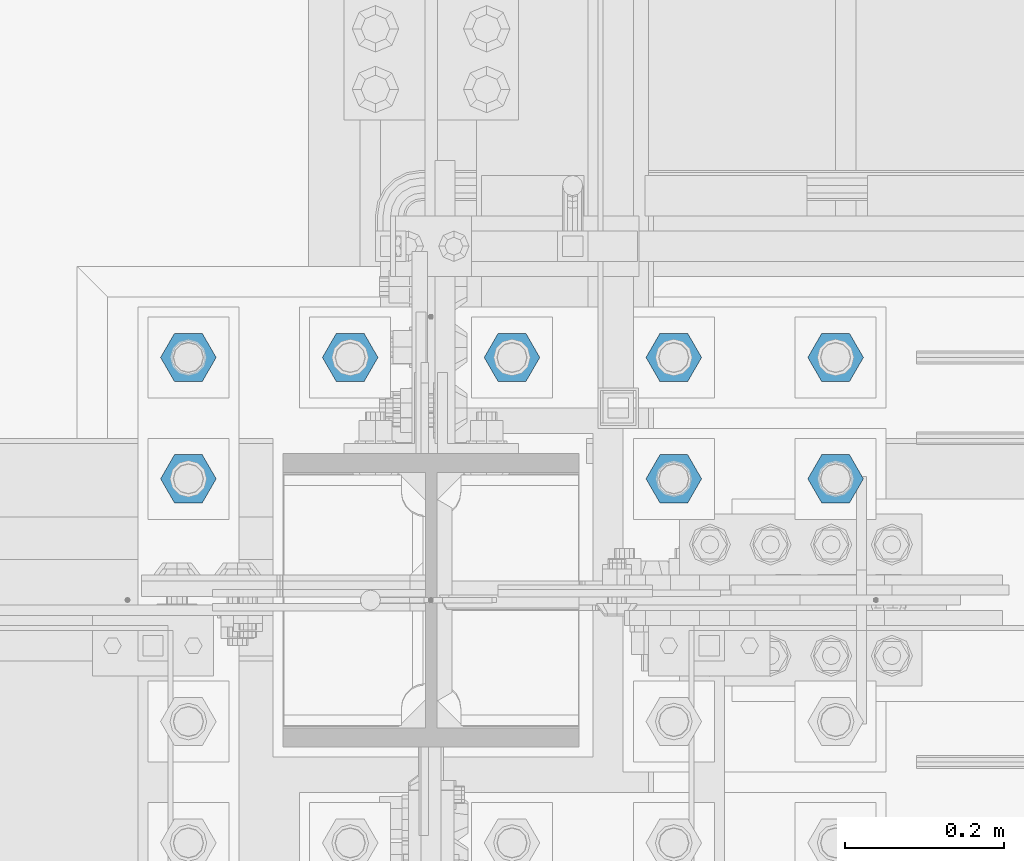
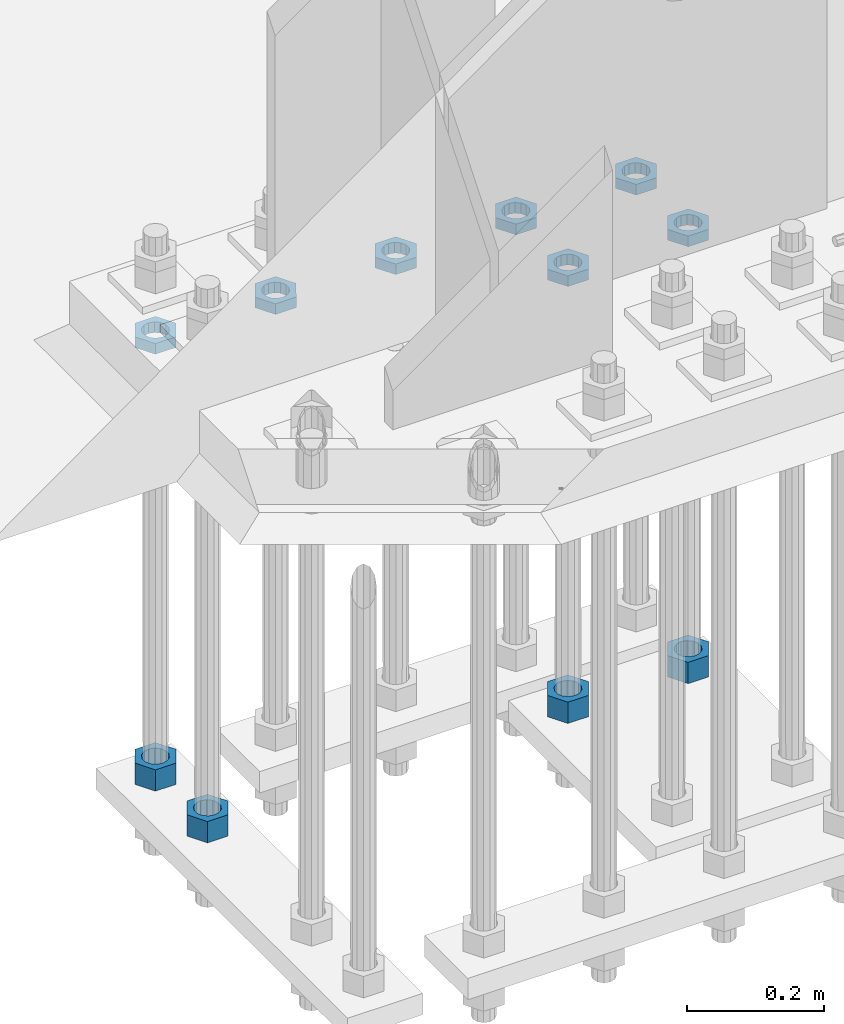
# One storey, part 2826 of 3843: 11 beams, 1 element without a shape of its own.
"""IFC2X3 building model written with IfcOpenShell, lengths in millimetres."""

from ifc_helpers import new_model, si_unit, frame, origin_with_axes, place, context, subcontext, project, spatial, faceted_brep, material, type_object, element, aggregate, save


model = new_model("IFC2X3")

# Units and contexts
model_context = context("Model", 3, precision=1e-05, world=origin_with_axes())
body_context = subcontext(model_context, "Body", "Model", "MODEL_VIEW")
ifc_project = project(units=[si_unit("LENGTHUNIT", "METRE", prefix="MILLI"), si_unit("AREAUNIT", "SQUARE_METRE"), si_unit("VOLUMEUNIT", "CUBIC_METRE"), si_unit("MASSUNIT", "GRAM", prefix="KILO"), si_unit("TIMEUNIT", "SECOND"), si_unit("PLANEANGLEUNIT", "RADIAN"), si_unit("SOLIDANGLEUNIT", "STERADIAN"), si_unit("THERMODYNAMICTEMPERATUREUNIT", "DEGREE_CELSIUS"), si_unit("LUMINOUSINTENSITYUNIT", "LUMEN")], contexts=[model_context])

# Site, building, storey
site_placement = place(None, origin_with_axes())
site = spatial("IfcSite", under=ifc_project, at=site_placement, CompositionType="ELEMENT")
building_placement = place(site_placement, origin_with_axes())
building = spatial("IfcBuilding", under=site, at=building_placement, Name="Undefined", CompositionType="ELEMENT")
storey_placement = place(building_placement, origin_with_axes())
storey = spatial("IfcBuildingStorey", under=building, at=storey_placement, Name="Undefined", CompositionType="ELEMENT", Elevation=0.0)

# Assembly, beams
assembly_placement = place(storey_placement, origin_with_axes())
assembly = element("IfcElementAssembly", 1, at=assembly_placement, inside=storey, Name="TEMPLATE", AssemblyPlace="NOTDEFINED", PredefinedType="RIGID_FRAME")
ifc_material = material(Name="STEEL/A572-50")
beam_type_1 = type_object("IfcBeamType", Name="1-1/2_HEAVY_HEX_NUT", PredefinedType="NOTDEFINED")
beam_1_placement = place(assembly_placement, frame((56438.8, 25768.3, 28841.7000015259), z_axis=(0.0, 1.0, 0.0), x_axis=(0.0, 0.0, -1.0)))
beam_1 = element("IfcBeam", 2, at=beam_1_placement, type_object=beam_type_1, material=ifc_material, Name="NUT", ObjectType="1-1/2_HEAVY_HEX_NUT", context=body_context, shape_type="Brep", body=[
    faceted_brep([(0.0, -34.9199981689453, 0.0), (0.0, -17.4599990844727, -30.25), (38.0999999999985, -17.4599990844727, -30.25), (38.0999999999985, -34.9199981689453, 0.0), (0.0, 17.4599990844727, -30.25), (38.0999999999985, 17.4599990844727, -30.25), (0.0, 34.9199981689453, 0.0), (38.0999999999985, 34.9199981689453, 0.0), (0.0, 17.4599990844727, 30.25), (38.0999999999985, 17.4599990844727, 30.25), (0.0, -17.4599990844727, 30.25), (38.0999999999985, -17.4599990844727, 30.25), (0.0, 0.0, 20.6399993896484), (0.0, 8.9553601105581, 18.5959968835959), (38.0999999999985, 8.9553601105581, 18.5959968835959), (38.0999999999985, 0.0, 20.6399993896484), (0.0, 16.1370013209525, 12.8688291298167), (38.0999999999985, 16.1370013209525, 12.8688291298167), (0.0, 20.1225115123816, 4.59283194104501), (38.0999999999985, 20.1225115123816, 4.59283194104501), (0.0, 20.1225115123816, -4.59283194104501), (38.0999999999985, 20.1225115123816, -4.59283194104501), (0.0, 16.1370013209525, -12.8688291298167), (38.0999999999985, 16.1370013209525, -12.8688291298167), (0.0, 8.9553601105581, -18.5959968835959), (38.0999999999985, 8.9553601105581, -18.5959968835959), (0.0, 0.0, -20.6399993896484), (38.0999999999985, 0.0, -20.6399993896484), (0.0, -8.9553601105581, -18.5959968835959), (38.0999999999985, -8.9553601105581, -18.5959968835959), (0.0, -16.1370013209525, -12.8688291298167), (38.0999999999985, -16.1370013209525, -12.8688291298167), (0.0, -20.1225115123816, -4.59283194104501), (38.0999999999985, -20.1225115123816, -4.59283194104501), (0.0, -20.1225115123816, 4.59283194104501), (38.0999999999985, -20.1225115123816, 4.59283194104501), (0.0, -16.1370013209525, 12.8688291298167), (38.0999999999985, -16.1370013209525, 12.8688291298167), (0.0, -8.9553601105581, 18.5959968835959), (38.0999999999985, -8.9553601105581, 18.5959968835959)], [[[0, 1, 2, 3]], [[1, 4, 5, 2]], [[4, 6, 7, 5]], [[6, 8, 9, 7]], [[8, 10, 11, 9]], [[10, 0, 3, 11]], [[12, 13, 14, 15]], [[13, 16, 17, 14]], [[16, 18, 19, 17]], [[18, 20, 21, 19]], [[20, 22, 23, 21]], [[22, 24, 25, 23]], [[24, 26, 27, 25]], [[26, 28, 29, 27]], [[28, 30, 31, 29]], [[30, 32, 33, 31]], [[32, 34, 35, 33]], [[34, 36, 37, 35]], [[36, 38, 39, 37]], [[38, 12, 15, 39]], [[5, 7, 9, 11, 3, 2], [17, 19, 21, 23, 25, 27, 29, 31, 33, 35, 37, 39, 15, 14]], [[10, 8, 6, 4, 1, 0], [38, 36, 34, 32, 30, 28, 26, 24, 22, 20, 18, 16, 13, 12]]]),
])
beam_2_placement = place(assembly_placement, frame((56235.6, 25768.3, 28841.7000015259), z_axis=(0.0, 1.0, 0.0), x_axis=(0.0, 0.0, -1.0)))
beam_2 = element("IfcBeam", 3, at=beam_2_placement, type_object=beam_type_1, material=ifc_material, Name="NUT", ObjectType="1-1/2_HEAVY_HEX_NUT", context=body_context, shape_type="Brep", body=[
    faceted_brep([(0.0, -34.9199981689453, 0.0), (0.0, -17.4599990844727, -30.25), (38.0999999999985, -17.4599990844727, -30.25), (38.0999999999985, -34.9199981689453, 0.0), (0.0, 17.4599990844727, -30.25), (38.0999999999985, 17.4599990844727, -30.25), (0.0, 34.9199981689453, 0.0), (38.0999999999985, 34.9199981689453, 0.0), (0.0, 17.4599990844727, 30.25), (38.0999999999985, 17.4599990844727, 30.25), (0.0, -17.4599990844727, 30.25), (38.0999999999985, -17.4599990844727, 30.25), (0.0, 0.0, 20.6399993896484), (0.0, 8.9553601105581, 18.5959968835959), (38.0999999999985, 8.9553601105581, 18.5959968835959), (38.0999999999985, 0.0, 20.6399993896484), (0.0, 16.1370013209525, 12.8688291298167), (38.0999999999985, 16.1370013209525, 12.8688291298167), (0.0, 20.1225115123816, 4.59283194104501), (38.0999999999985, 20.1225115123816, 4.59283194104501), (0.0, 20.1225115123816, -4.59283194104501), (38.0999999999985, 20.1225115123816, -4.59283194104501), (0.0, 16.1370013209525, -12.8688291298167), (38.0999999999985, 16.1370013209525, -12.8688291298167), (0.0, 8.9553601105581, -18.5959968835959), (38.0999999999985, 8.9553601105581, -18.5959968835959), (0.0, 0.0, -20.6399993896484), (38.0999999999985, 0.0, -20.6399993896484), (0.0, -8.9553601105581, -18.5959968835959), (38.0999999999985, -8.9553601105581, -18.5959968835959), (0.0, -16.1370013209525, -12.8688291298167), (38.0999999999985, -16.1370013209525, -12.8688291298167), (0.0, -20.1225115123816, -4.59283194104501), (38.0999999999985, -20.1225115123816, -4.59283194104501), (0.0, -20.1225115123816, 4.59283194104501), (38.0999999999985, -20.1225115123816, 4.59283194104501), (0.0, -16.1370013209525, 12.8688291298167), (38.0999999999985, -16.1370013209525, 12.8688291298167), (0.0, -8.9553601105581, 18.5959968835959), (38.0999999999985, -8.9553601105581, 18.5959968835959)], [[[0, 1, 2, 3]], [[1, 4, 5, 2]], [[4, 6, 7, 5]], [[6, 8, 9, 7]], [[8, 10, 11, 9]], [[10, 0, 3, 11]], [[12, 13, 14, 15]], [[13, 16, 17, 14]], [[16, 18, 19, 17]], [[18, 20, 21, 19]], [[20, 22, 23, 21]], [[22, 24, 25, 23]], [[24, 26, 27, 25]], [[26, 28, 29, 27]], [[28, 30, 31, 29]], [[30, 32, 33, 31]], [[32, 34, 35, 33]], [[34, 36, 37, 35]], [[36, 38, 39, 37]], [[38, 12, 15, 39]], [[5, 7, 9, 11, 3, 2], [17, 19, 21, 23, 25, 27, 29, 31, 33, 35, 37, 39, 15, 14]], [[10, 8, 6, 4, 1, 0], [38, 36, 34, 32, 30, 28, 26, 24, 22, 20, 18, 16, 13, 12]]]),
])
beam_3_placement = place(assembly_placement, frame((55626.0, 25920.7, 28841.7000015259), z_axis=(0.0, -1.0, 0.0), x_axis=(0.0, 0.0, -1.0)))
beam_3 = element("IfcBeam", 4, at=beam_3_placement, type_object=beam_type_1, material=ifc_material, Name="NUT", ObjectType="1-1/2_HEAVY_HEX_NUT", context=body_context, shape_type="Brep", body=[
    faceted_brep([(0.0, -34.9199981689453, 0.0), (0.0, -17.4599990844727, -30.25), (38.0999999999985, -17.4599990844727, -30.25), (38.0999999999985, -34.9199981689453, 0.0), (0.0, 17.4599990844727, -30.25), (38.0999999999985, 17.4599990844727, -30.25), (0.0, 34.9199981689453, 0.0), (38.0999999999985, 34.9199981689453, 0.0), (0.0, 17.4599990844727, 30.25), (38.0999999999985, 17.4599990844727, 30.25), (0.0, -17.4599990844727, 30.25), (38.0999999999985, -17.4599990844727, 30.25), (0.0, 0.0, 20.6399993896484), (0.0, 8.9553601105581, 18.5959968835959), (38.0999999999985, 8.9553601105581, 18.5959968835959), (38.0999999999985, 0.0, 20.6399993896484), (0.0, 16.1370013209525, 12.8688291298167), (38.0999999999985, 16.1370013209525, 12.8688291298167), (0.0, 20.1225115123816, 4.59283194104501), (38.0999999999985, 20.1225115123816, 4.59283194104501), (0.0, 20.1225115123816, -4.59283194104501), (38.0999999999985, 20.1225115123816, -4.59283194104501), (0.0, 16.1370013209525, -12.8688291298167), (38.0999999999985, 16.1370013209525, -12.8688291298167), (0.0, 8.9553601105581, -18.5959968835959), (38.0999999999985, 8.9553601105581, -18.5959968835959), (0.0, 0.0, -20.6399993896484), (38.0999999999985, 0.0, -20.6399993896484), (0.0, -8.9553601105581, -18.5959968835959), (38.0999999999985, -8.9553601105581, -18.5959968835959), (0.0, -16.1370013209525, -12.8688291298167), (38.0999999999985, -16.1370013209525, -12.8688291298167), (0.0, -20.1225115123816, -4.59283194104501), (38.0999999999985, -20.1225115123816, -4.59283194104501), (0.0, -20.1225115123816, 4.59283194104501), (38.0999999999985, -20.1225115123816, 4.59283194104501), (0.0, -16.1370013209525, 12.8688291298167), (38.0999999999985, -16.1370013209525, 12.8688291298167), (0.0, -8.9553601105581, 18.5959968835959), (38.0999999999985, -8.9553601105581, 18.5959968835959)], [[[0, 1, 2, 3]], [[1, 4, 5, 2]], [[4, 6, 7, 5]], [[6, 8, 9, 7]], [[8, 10, 11, 9]], [[10, 0, 3, 11]], [[12, 13, 14, 15]], [[13, 16, 17, 14]], [[16, 18, 19, 17]], [[18, 20, 21, 19]], [[20, 22, 23, 21]], [[22, 24, 25, 23]], [[24, 26, 27, 25]], [[26, 28, 29, 27]], [[28, 30, 31, 29]], [[30, 32, 33, 31]], [[32, 34, 35, 33]], [[34, 36, 37, 35]], [[36, 38, 39, 37]], [[38, 12, 15, 39]], [[5, 7, 9, 11, 3, 2], [17, 19, 21, 23, 25, 27, 29, 31, 33, 35, 37, 39, 15, 14]], [[10, 8, 6, 4, 1, 0], [38, 36, 34, 32, 30, 28, 26, 24, 22, 20, 18, 16, 13, 12]]]),
])
beam_4_placement = place(assembly_placement, frame((55626.0, 25768.3, 28841.7000015259), z_axis=(0.0, -1.0, 0.0), x_axis=(0.0, 0.0, -1.0)))
beam_4 = element("IfcBeam", 5, at=beam_4_placement, type_object=beam_type_1, material=ifc_material, Name="NUT", ObjectType="1-1/2_HEAVY_HEX_NUT", context=body_context, shape_type="Brep", body=[
    faceted_brep([(0.0, -34.9199981689453, 0.0), (0.0, -17.4599990844727, -30.25), (38.0999999999985, -17.4599990844727, -30.25), (38.0999999999985, -34.9199981689453, 0.0), (0.0, 17.4599990844727, -30.25), (38.0999999999985, 17.4599990844727, -30.25), (0.0, 34.9199981689453, 0.0), (38.0999999999985, 34.9199981689453, 0.0), (0.0, 17.4599990844727, 30.25), (38.0999999999985, 17.4599990844727, 30.25), (0.0, -17.4599990844727, 30.25), (38.0999999999985, -17.4599990844727, 30.25), (0.0, 0.0, 20.6399993896484), (0.0, 8.9553601105581, 18.5959968835959), (38.0999999999985, 8.9553601105581, 18.5959968835959), (38.0999999999985, 0.0, 20.6399993896484), (0.0, 16.1370013209525, 12.8688291298167), (38.0999999999985, 16.1370013209525, 12.8688291298167), (0.0, 20.1225115123816, 4.59283194104501), (38.0999999999985, 20.1225115123816, 4.59283194104501), (0.0, 20.1225115123816, -4.59283194104501), (38.0999999999985, 20.1225115123816, -4.59283194104501), (0.0, 16.1370013209525, -12.8688291298167), (38.0999999999985, 16.1370013209525, -12.8688291298167), (0.0, 8.9553601105581, -18.5959968835959), (38.0999999999985, 8.9553601105581, -18.5959968835959), (0.0, 0.0, -20.6399993896484), (38.0999999999985, 0.0, -20.6399993896484), (0.0, -8.9553601105581, -18.5959968835959), (38.0999999999985, -8.9553601105581, -18.5959968835959), (0.0, -16.1370013209525, -12.8688291298167), (38.0999999999985, -16.1370013209525, -12.8688291298167), (0.0, -20.1225115123816, -4.59283194104501), (38.0999999999985, -20.1225115123816, -4.59283194104501), (0.0, -20.1225115123816, 4.59283194104501), (38.0999999999985, -20.1225115123816, 4.59283194104501), (0.0, -16.1370013209525, 12.8688291298167), (38.0999999999985, -16.1370013209525, 12.8688291298167), (0.0, -8.9553601105581, 18.5959968835959), (38.0999999999985, -8.9553601105581, 18.5959968835959)], [[[0, 1, 2, 3]], [[1, 4, 5, 2]], [[4, 6, 7, 5]], [[6, 8, 9, 7]], [[8, 10, 11, 9]], [[10, 0, 3, 11]], [[12, 13, 14, 15]], [[13, 16, 17, 14]], [[16, 18, 19, 17]], [[18, 20, 21, 19]], [[20, 22, 23, 21]], [[22, 24, 25, 23]], [[24, 26, 27, 25]], [[26, 28, 29, 27]], [[28, 30, 31, 29]], [[30, 32, 33, 31]], [[32, 34, 35, 33]], [[34, 36, 37, 35]], [[36, 38, 39, 37]], [[38, 12, 15, 39]], [[5, 7, 9, 11, 3, 2], [17, 19, 21, 23, 25, 27, 29, 31, 33, 35, 37, 39, 15, 14]], [[10, 8, 6, 4, 1, 0], [38, 36, 34, 32, 30, 28, 26, 24, 22, 20, 18, 16, 13, 12]]]),
])
beam_type_2 = type_object("IfcBeamType", Name="1-1/2_HALF_NUT", PredefinedType="NOTDEFINED")
beam_5_placement = place(assembly_placement, frame((56438.8, 25768.3, 29603.7), z_axis=(0.0, 1.0, 0.0), x_axis=(0.0, 0.0, -1.0)))
beam_5 = element("IfcBeam", 6, at=beam_5_placement, type_object=beam_type_2, material=ifc_material, Name="NUT", ObjectType="1-1/2_HALF_NUT", context=body_context, shape_type="Brep", body=[
    faceted_brep([(0.0, -34.9199981689453, 0.0), (0.0, -17.4599990844727, -30.25), (19.0500000000029, -17.4599990844727, -30.25), (19.0500000000029, -34.9199981689453, 0.0), (0.0, 17.4599990844727, -30.25), (19.0500000000029, 17.4599990844727, -30.25), (0.0, 34.9199981689453, 0.0), (19.0500000000029, 34.9199981689453, 0.0), (0.0, 17.4599990844727, 30.25), (19.0500000000029, 17.4599990844727, 30.25), (0.0, -17.4599990844727, 30.25), (19.0500000000029, -17.4599990844727, 30.25), (0.0, 0.0, 20.6399993896484), (0.0, 8.9553601105581, 18.5959968835959), (19.0500000000029, 8.95536011056538, 18.5959968835959), (19.0500000000029, 0.0, 20.6399993896484), (0.0, 16.1370013209525, 12.8688291298167), (19.0500000000029, 16.1370013209489, 12.8688291298167), (0.0, 20.1225115123816, 4.59283194104501), (19.0500000000029, 20.1225115123852, 4.59283194104501), (0.0, 20.1225115123816, -4.59283194104501), (19.0500000000029, 20.1225115123852, -4.59283194104501), (0.0, 16.1370013209525, -12.8688291298167), (19.0500000000029, 16.1370013209489, -12.8688291298167), (0.0, 8.9553601105581, -18.5959968835959), (19.0500000000029, 8.95536011056538, -18.5959968835959), (0.0, 0.0, -20.6399993896484), (19.0500000000029, 0.0, -20.6399993896484), (0.0, -8.9553601105581, -18.5959968835959), (19.0500000000029, -8.95536011056538, -18.5959968835959), (0.0, -16.1370013209525, -12.8688291298167), (19.0500000000029, -16.1370013209489, -12.8688291298167), (0.0, -20.1225115123816, -4.59283194104501), (19.0500000000029, -20.1225115123852, -4.59283194104501), (0.0, -20.1225115123816, 4.59283194104501), (19.0500000000029, -20.1225115123852, 4.59283194104501), (0.0, -16.1370013209525, 12.8688291298167), (19.0500000000029, -16.1370013209489, 12.8688291298167), (0.0, -8.9553601105581, 18.5959968835959), (19.0500000000029, -8.95536011056538, 18.5959968835959)], [[[0, 1, 2, 3]], [[1, 4, 5, 2]], [[4, 6, 7, 5]], [[6, 8, 9, 7]], [[8, 10, 11, 9]], [[10, 0, 3, 11]], [[12, 13, 14, 15]], [[13, 16, 17, 14]], [[16, 18, 19, 17]], [[18, 20, 21, 19]], [[20, 22, 23, 21]], [[22, 24, 25, 23]], [[24, 26, 27, 25]], [[26, 28, 29, 27]], [[28, 30, 31, 29]], [[30, 32, 33, 31]], [[32, 34, 35, 33]], [[34, 36, 37, 35]], [[36, 38, 39, 37]], [[38, 12, 15, 39]], [[5, 7, 9, 11, 3, 2], [17, 19, 21, 23, 25, 27, 29, 31, 33, 35, 37, 39, 15, 14]], [[10, 8, 6, 4, 1, 0], [38, 36, 34, 32, 30, 28, 26, 24, 22, 20, 18, 16, 13, 12]]]),
])
beam_6_placement = place(assembly_placement, frame((56438.8, 25920.7, 29603.7), z_axis=(0.0, 1.0, 0.0), x_axis=(0.0, 0.0, -1.0)))
beam_6 = element("IfcBeam", 7, at=beam_6_placement, type_object=beam_type_2, material=ifc_material, Name="NUT", ObjectType="1-1/2_HALF_NUT", context=body_context, shape_type="Brep", body=[
    faceted_brep([(0.0, -34.9199981689453, 0.0), (0.0, -17.4599990844727, -30.25), (19.0500000000029, -17.4599990844727, -30.25), (19.0500000000029, -34.9199981689453, 0.0), (0.0, 17.4599990844727, -30.25), (19.0500000000029, 17.4599990844727, -30.25), (0.0, 34.9199981689453, 0.0), (19.0500000000029, 34.9199981689453, 0.0), (0.0, 17.4599990844727, 30.25), (19.0500000000029, 17.4599990844727, 30.25), (0.0, -17.4599990844727, 30.25), (19.0500000000029, -17.4599990844727, 30.25), (0.0, 0.0, 20.6399993896484), (0.0, 8.9553601105581, 18.5959968835959), (19.0500000000029, 8.95536011056538, 18.5959968835959), (19.0500000000029, 0.0, 20.6399993896484), (0.0, 16.1370013209525, 12.8688291298167), (19.0500000000029, 16.1370013209489, 12.8688291298167), (0.0, 20.1225115123816, 4.59283194104501), (19.0500000000029, 20.1225115123852, 4.59283194104501), (0.0, 20.1225115123816, -4.59283194104501), (19.0500000000029, 20.1225115123852, -4.59283194104501), (0.0, 16.1370013209525, -12.8688291298167), (19.0500000000029, 16.1370013209489, -12.8688291298167), (0.0, 8.9553601105581, -18.5959968835959), (19.0500000000029, 8.95536011056538, -18.5959968835959), (0.0, 0.0, -20.6399993896484), (19.0500000000029, 0.0, -20.6399993896484), (0.0, -8.9553601105581, -18.5959968835959), (19.0500000000029, -8.95536011056538, -18.5959968835959), (0.0, -16.1370013209525, -12.8688291298167), (19.0500000000029, -16.1370013209489, -12.8688291298167), (0.0, -20.1225115123816, -4.59283194104501), (19.0500000000029, -20.1225115123852, -4.59283194104501), (0.0, -20.1225115123816, 4.59283194104501), (19.0500000000029, -20.1225115123852, 4.59283194104501), (0.0, -16.1370013209525, 12.8688291298167), (19.0500000000029, -16.1370013209489, 12.8688291298167), (0.0, -8.9553601105581, 18.5959968835959), (19.0500000000029, -8.95536011056538, 18.5959968835959)], [[[0, 1, 2, 3]], [[1, 4, 5, 2]], [[4, 6, 7, 5]], [[6, 8, 9, 7]], [[8, 10, 11, 9]], [[10, 0, 3, 11]], [[12, 13, 14, 15]], [[13, 16, 17, 14]], [[16, 18, 19, 17]], [[18, 20, 21, 19]], [[20, 22, 23, 21]], [[22, 24, 25, 23]], [[24, 26, 27, 25]], [[26, 28, 29, 27]], [[28, 30, 31, 29]], [[30, 32, 33, 31]], [[32, 34, 35, 33]], [[34, 36, 37, 35]], [[36, 38, 39, 37]], [[38, 12, 15, 39]], [[5, 7, 9, 11, 3, 2], [17, 19, 21, 23, 25, 27, 29, 31, 33, 35, 37, 39, 15, 14]], [[10, 8, 6, 4, 1, 0], [38, 36, 34, 32, 30, 28, 26, 24, 22, 20, 18, 16, 13, 12]]]),
])
beam_7_placement = place(assembly_placement, frame((56235.6, 25920.7, 29603.7), z_axis=(0.0, 1.0, 0.0), x_axis=(0.0, 0.0, -1.0)))
beam_7 = element("IfcBeam", 8, at=beam_7_placement, type_object=beam_type_2, material=ifc_material, Name="NUT", ObjectType="1-1/2_HALF_NUT", context=body_context, shape_type="Brep", body=[
    faceted_brep([(0.0, -34.9199981689453, 0.0), (0.0, -17.4599990844727, -30.25), (19.0500000000029, -17.4599990844727, -30.25), (19.0500000000029, -34.9199981689453, 0.0), (0.0, 17.4599990844727, -30.25), (19.0500000000029, 17.4599990844727, -30.25), (0.0, 34.9199981689453, 0.0), (19.0500000000029, 34.9199981689453, 0.0), (0.0, 17.4599990844727, 30.25), (19.0500000000029, 17.4599990844727, 30.25), (0.0, -17.4599990844727, 30.25), (19.0500000000029, -17.4599990844727, 30.25), (0.0, 0.0, 20.6399993896484), (0.0, 8.9553601105581, 18.5959968835959), (19.0500000000029, 8.95536011056538, 18.5959968835959), (19.0500000000029, 0.0, 20.6399993896484), (0.0, 16.1370013209525, 12.8688291298167), (19.0500000000029, 16.1370013209489, 12.8688291298167), (0.0, 20.1225115123816, 4.59283194104501), (19.0500000000029, 20.1225115123852, 4.59283194104501), (0.0, 20.1225115123816, -4.59283194104501), (19.0500000000029, 20.1225115123852, -4.59283194104501), (0.0, 16.1370013209525, -12.8688291298167), (19.0500000000029, 16.1370013209489, -12.8688291298167), (0.0, 8.9553601105581, -18.5959968835959), (19.0500000000029, 8.95536011056538, -18.5959968835959), (0.0, 0.0, -20.6399993896484), (19.0500000000029, 0.0, -20.6399993896484), (0.0, -8.9553601105581, -18.5959968835959), (19.0500000000029, -8.95536011056538, -18.5959968835959), (0.0, -16.1370013209525, -12.8688291298167), (19.0500000000029, -16.1370013209489, -12.8688291298167), (0.0, -20.1225115123816, -4.59283194104501), (19.0500000000029, -20.1225115123852, -4.59283194104501), (0.0, -20.1225115123816, 4.59283194104501), (19.0500000000029, -20.1225115123852, 4.59283194104501), (0.0, -16.1370013209525, 12.8688291298167), (19.0500000000029, -16.1370013209489, 12.8688291298167), (0.0, -8.9553601105581, 18.5959968835959), (19.0500000000029, -8.95536011056538, 18.5959968835959)], [[[0, 1, 2, 3]], [[1, 4, 5, 2]], [[4, 6, 7, 5]], [[6, 8, 9, 7]], [[8, 10, 11, 9]], [[10, 0, 3, 11]], [[12, 13, 14, 15]], [[13, 16, 17, 14]], [[16, 18, 19, 17]], [[18, 20, 21, 19]], [[20, 22, 23, 21]], [[22, 24, 25, 23]], [[24, 26, 27, 25]], [[26, 28, 29, 27]], [[28, 30, 31, 29]], [[30, 32, 33, 31]], [[32, 34, 35, 33]], [[34, 36, 37, 35]], [[36, 38, 39, 37]], [[38, 12, 15, 39]], [[5, 7, 9, 11, 3, 2], [17, 19, 21, 23, 25, 27, 29, 31, 33, 35, 37, 39, 15, 14]], [[10, 8, 6, 4, 1, 0], [38, 36, 34, 32, 30, 28, 26, 24, 22, 20, 18, 16, 13, 12]]]),
])
beam_8_placement = place(assembly_placement, frame((56235.6, 25768.3, 29603.7), z_axis=(0.0, 1.0, 0.0), x_axis=(0.0, 0.0, -1.0)))
beam_8 = element("IfcBeam", 9, at=beam_8_placement, type_object=beam_type_2, material=ifc_material, Name="NUT", ObjectType="1-1/2_HALF_NUT", context=body_context, shape_type="Brep", body=[
    faceted_brep([(0.0, -34.9199981689453, 0.0), (0.0, -17.4599990844727, -30.25), (19.0500000000029, -17.4599990844727, -30.25), (19.0500000000029, -34.9199981689453, 0.0), (0.0, 17.4599990844727, -30.25), (19.0500000000029, 17.4599990844727, -30.25), (0.0, 34.9199981689453, 0.0), (19.0500000000029, 34.9199981689453, 0.0), (0.0, 17.4599990844727, 30.25), (19.0500000000029, 17.4599990844727, 30.25), (0.0, -17.4599990844727, 30.25), (19.0500000000029, -17.4599990844727, 30.25), (0.0, 0.0, 20.6399993896484), (0.0, 8.9553601105581, 18.5959968835959), (19.0500000000029, 8.95536011056538, 18.5959968835959), (19.0500000000029, 0.0, 20.6399993896484), (0.0, 16.1370013209525, 12.8688291298167), (19.0500000000029, 16.1370013209489, 12.8688291298167), (0.0, 20.1225115123816, 4.59283194104501), (19.0500000000029, 20.1225115123852, 4.59283194104501), (0.0, 20.1225115123816, -4.59283194104501), (19.0500000000029, 20.1225115123852, -4.59283194104501), (0.0, 16.1370013209525, -12.8688291298167), (19.0500000000029, 16.1370013209489, -12.8688291298167), (0.0, 8.9553601105581, -18.5959968835959), (19.0500000000029, 8.95536011056538, -18.5959968835959), (0.0, 0.0, -20.6399993896484), (19.0500000000029, 0.0, -20.6399993896484), (0.0, -8.9553601105581, -18.5959968835959), (19.0500000000029, -8.95536011056538, -18.5959968835959), (0.0, -16.1370013209525, -12.8688291298167), (19.0500000000029, -16.1370013209489, -12.8688291298167), (0.0, -20.1225115123816, -4.59283194104501), (19.0500000000029, -20.1225115123852, -4.59283194104501), (0.0, -20.1225115123816, 4.59283194104501), (19.0500000000029, -20.1225115123852, 4.59283194104501), (0.0, -16.1370013209525, 12.8688291298167), (19.0500000000029, -16.1370013209489, 12.8688291298167), (0.0, -8.9553601105581, 18.5959968835959), (19.0500000000029, -8.95536011056538, 18.5959968835959)], [[[0, 1, 2, 3]], [[1, 4, 5, 2]], [[4, 6, 7, 5]], [[6, 8, 9, 7]], [[8, 10, 11, 9]], [[10, 0, 3, 11]], [[12, 13, 14, 15]], [[13, 16, 17, 14]], [[16, 18, 19, 17]], [[18, 20, 21, 19]], [[20, 22, 23, 21]], [[22, 24, 25, 23]], [[24, 26, 27, 25]], [[26, 28, 29, 27]], [[28, 30, 31, 29]], [[30, 32, 33, 31]], [[32, 34, 35, 33]], [[34, 36, 37, 35]], [[36, 38, 39, 37]], [[38, 12, 15, 39]], [[5, 7, 9, 11, 3, 2], [17, 19, 21, 23, 25, 27, 29, 31, 33, 35, 37, 39, 15, 14]], [[10, 8, 6, 4, 1, 0], [38, 36, 34, 32, 30, 28, 26, 24, 22, 20, 18, 16, 13, 12]]]),
])
beam_9_placement = place(assembly_placement, frame((56032.4, 25920.7, 29603.7), z_axis=(0.0, -1.0, 0.0), x_axis=(0.0, 0.0, -1.0)))
beam_9 = element("IfcBeam", 10, at=beam_9_placement, type_object=beam_type_2, material=ifc_material, Name="NUT", ObjectType="1-1/2_HALF_NUT", context=body_context, shape_type="Brep", body=[
    faceted_brep([(0.0, -34.9199981689453, 0.0), (0.0, -17.4599990844727, -30.25), (19.0500000000029, -17.4599990844727, -30.25), (19.0500000000029, -34.9199981689453, 0.0), (0.0, 17.4599990844727, -30.25), (19.0500000000029, 17.4599990844727, -30.25), (0.0, 34.9199981689453, 0.0), (19.0500000000029, 34.9199981689453, 0.0), (0.0, 17.4599990844727, 30.25), (19.0500000000029, 17.4599990844727, 30.25), (0.0, -17.4599990844727, 30.25), (19.0500000000029, -17.4599990844727, 30.25), (0.0, 0.0, 20.6399993896484), (0.0, 8.9553601105581, 18.5959968835959), (19.0500000000029, 8.95536011056538, 18.5959968835959), (19.0500000000029, 0.0, 20.6399993896484), (0.0, 16.1370013209525, 12.8688291298167), (19.0500000000029, 16.1370013209489, 12.8688291298167), (0.0, 20.1225115123816, 4.59283194104501), (19.0500000000029, 20.1225115123852, 4.59283194104501), (0.0, 20.1225115123816, -4.59283194104501), (19.0500000000029, 20.1225115123852, -4.59283194104501), (0.0, 16.1370013209525, -12.8688291298167), (19.0500000000029, 16.1370013209489, -12.8688291298167), (0.0, 8.9553601105581, -18.5959968835959), (19.0500000000029, 8.95536011056538, -18.5959968835959), (0.0, 0.0, -20.6399993896484), (19.0500000000029, 0.0, -20.6399993896484), (0.0, -8.9553601105581, -18.5959968835959), (19.0500000000029, -8.95536011056538, -18.5959968835959), (0.0, -16.1370013209525, -12.8688291298167), (19.0500000000029, -16.1370013209489, -12.8688291298167), (0.0, -20.1225115123816, -4.59283194104501), (19.0500000000029, -20.1225115123852, -4.59283194104501), (0.0, -20.1225115123816, 4.59283194104501), (19.0500000000029, -20.1225115123852, 4.59283194104501), (0.0, -16.1370013209525, 12.8688291298167), (19.0500000000029, -16.1370013209489, 12.8688291298167), (0.0, -8.9553601105581, 18.5959968835959), (19.0500000000029, -8.95536011056538, 18.5959968835959)], [[[0, 1, 2, 3]], [[1, 4, 5, 2]], [[4, 6, 7, 5]], [[6, 8, 9, 7]], [[8, 10, 11, 9]], [[10, 0, 3, 11]], [[12, 13, 14, 15]], [[13, 16, 17, 14]], [[16, 18, 19, 17]], [[18, 20, 21, 19]], [[20, 22, 23, 21]], [[22, 24, 25, 23]], [[24, 26, 27, 25]], [[26, 28, 29, 27]], [[28, 30, 31, 29]], [[30, 32, 33, 31]], [[32, 34, 35, 33]], [[34, 36, 37, 35]], [[36, 38, 39, 37]], [[38, 12, 15, 39]], [[5, 7, 9, 11, 3, 2], [17, 19, 21, 23, 25, 27, 29, 31, 33, 35, 37, 39, 15, 14]], [[10, 8, 6, 4, 1, 0], [38, 36, 34, 32, 30, 28, 26, 24, 22, 20, 18, 16, 13, 12]]]),
])
beam_10_placement = place(assembly_placement, frame((55829.2, 25920.7, 29603.7), z_axis=(0.0, -1.0, 0.0), x_axis=(0.0, 0.0, -1.0)))
beam_10 = element("IfcBeam", 11, at=beam_10_placement, type_object=beam_type_2, material=ifc_material, Name="NUT", ObjectType="1-1/2_HALF_NUT", context=body_context, shape_type="Brep", body=[
    faceted_brep([(0.0, -34.9199981689453, 0.0), (0.0, -17.4599990844727, -30.25), (19.0500000000029, -17.4599990844727, -30.25), (19.0500000000029, -34.9199981689453, 0.0), (0.0, 17.4599990844727, -30.25), (19.0500000000029, 17.4599990844727, -30.25), (0.0, 34.9199981689453, 0.0), (19.0500000000029, 34.9199981689453, 0.0), (0.0, 17.4599990844727, 30.25), (19.0500000000029, 17.4599990844727, 30.25), (0.0, -17.4599990844727, 30.25), (19.0500000000029, -17.4599990844727, 30.25), (0.0, 0.0, 20.6399993896484), (0.0, 8.9553601105581, 18.5959968835959), (19.0500000000029, 8.95536011056538, 18.5959968835959), (19.0500000000029, 0.0, 20.6399993896484), (0.0, 16.1370013209525, 12.8688291298167), (19.0500000000029, 16.1370013209489, 12.8688291298167), (0.0, 20.1225115123816, 4.59283194104501), (19.0500000000029, 20.1225115123852, 4.59283194104501), (0.0, 20.1225115123816, -4.59283194104501), (19.0500000000029, 20.1225115123852, -4.59283194104501), (0.0, 16.1370013209525, -12.8688291298167), (19.0500000000029, 16.1370013209489, -12.8688291298167), (0.0, 8.9553601105581, -18.5959968835959), (19.0500000000029, 8.95536011056538, -18.5959968835959), (0.0, 0.0, -20.6399993896484), (19.0500000000029, 0.0, -20.6399993896484), (0.0, -8.9553601105581, -18.5959968835959), (19.0500000000029, -8.95536011056538, -18.5959968835959), (0.0, -16.1370013209525, -12.8688291298167), (19.0500000000029, -16.1370013209489, -12.8688291298167), (0.0, -20.1225115123816, -4.59283194104501), (19.0500000000029, -20.1225115123852, -4.59283194104501), (0.0, -20.1225115123816, 4.59283194104501), (19.0500000000029, -20.1225115123852, 4.59283194104501), (0.0, -16.1370013209525, 12.8688291298167), (19.0500000000029, -16.1370013209489, 12.8688291298167), (0.0, -8.9553601105581, 18.5959968835959), (19.0500000000029, -8.95536011056538, 18.5959968835959)], [[[0, 1, 2, 3]], [[1, 4, 5, 2]], [[4, 6, 7, 5]], [[6, 8, 9, 7]], [[8, 10, 11, 9]], [[10, 0, 3, 11]], [[12, 13, 14, 15]], [[13, 16, 17, 14]], [[16, 18, 19, 17]], [[18, 20, 21, 19]], [[20, 22, 23, 21]], [[22, 24, 25, 23]], [[24, 26, 27, 25]], [[26, 28, 29, 27]], [[28, 30, 31, 29]], [[30, 32, 33, 31]], [[32, 34, 35, 33]], [[34, 36, 37, 35]], [[36, 38, 39, 37]], [[38, 12, 15, 39]], [[5, 7, 9, 11, 3, 2], [17, 19, 21, 23, 25, 27, 29, 31, 33, 35, 37, 39, 15, 14]], [[10, 8, 6, 4, 1, 0], [38, 36, 34, 32, 30, 28, 26, 24, 22, 20, 18, 16, 13, 12]]]),
])
beam_11_placement = place(assembly_placement, frame((55626.0, 25920.7, 29603.7), z_axis=(0.0, -1.0, 0.0), x_axis=(0.0, 0.0, -1.0)))
beam_11 = element("IfcBeam", 12, at=beam_11_placement, type_object=beam_type_2, material=ifc_material, Name="NUT", ObjectType="1-1/2_HALF_NUT", context=body_context, shape_type="Brep", body=[
    faceted_brep([(0.0, -34.9199981689453, 0.0), (0.0, -17.4599990844727, -30.25), (19.0500000000029, -17.4599990844727, -30.25), (19.0500000000029, -34.9199981689453, 0.0), (0.0, 17.4599990844727, -30.25), (19.0500000000029, 17.4599990844727, -30.25), (0.0, 34.9199981689453, 0.0), (19.0500000000029, 34.9199981689453, 0.0), (0.0, 17.4599990844727, 30.25), (19.0500000000029, 17.4599990844727, 30.25), (0.0, -17.4599990844727, 30.25), (19.0500000000029, -17.4599990844727, 30.25), (0.0, 0.0, 20.6399993896484), (0.0, 8.9553601105581, 18.5959968835959), (19.0500000000029, 8.95536011056538, 18.5959968835959), (19.0500000000029, 0.0, 20.6399993896484), (0.0, 16.1370013209525, 12.8688291298167), (19.0500000000029, 16.1370013209489, 12.8688291298167), (0.0, 20.1225115123816, 4.59283194104501), (19.0500000000029, 20.1225115123852, 4.59283194104501), (0.0, 20.1225115123816, -4.59283194104501), (19.0500000000029, 20.1225115123852, -4.59283194104501), (0.0, 16.1370013209525, -12.8688291298167), (19.0500000000029, 16.1370013209489, -12.8688291298167), (0.0, 8.9553601105581, -18.5959968835959), (19.0500000000029, 8.95536011056538, -18.5959968835959), (0.0, 0.0, -20.6399993896484), (19.0500000000029, 0.0, -20.6399993896484), (0.0, -8.9553601105581, -18.5959968835959), (19.0500000000029, -8.95536011056538, -18.5959968835959), (0.0, -16.1370013209525, -12.8688291298167), (19.0500000000029, -16.1370013209489, -12.8688291298167), (0.0, -20.1225115123816, -4.59283194104501), (19.0500000000029, -20.1225115123852, -4.59283194104501), (0.0, -20.1225115123816, 4.59283194104501), (19.0500000000029, -20.1225115123852, 4.59283194104501), (0.0, -16.1370013209525, 12.8688291298167), (19.0500000000029, -16.1370013209489, 12.8688291298167), (0.0, -8.9553601105581, 18.5959968835959), (19.0500000000029, -8.95536011056538, 18.5959968835959)], [[[0, 1, 2, 3]], [[1, 4, 5, 2]], [[4, 6, 7, 5]], [[6, 8, 9, 7]], [[8, 10, 11, 9]], [[10, 0, 3, 11]], [[12, 13, 14, 15]], [[13, 16, 17, 14]], [[16, 18, 19, 17]], [[18, 20, 21, 19]], [[20, 22, 23, 21]], [[22, 24, 25, 23]], [[24, 26, 27, 25]], [[26, 28, 29, 27]], [[28, 30, 31, 29]], [[30, 32, 33, 31]], [[32, 34, 35, 33]], [[34, 36, 37, 35]], [[36, 38, 39, 37]], [[38, 12, 15, 39]], [[5, 7, 9, 11, 3, 2], [17, 19, 21, 23, 25, 27, 29, 31, 33, 35, 37, 39, 15, 14]], [[10, 8, 6, 4, 1, 0], [38, 36, 34, 32, 30, 28, 26, 24, 22, 20, 18, 16, 13, 12]]]),
])
aggregate(assembly, [beam_1, beam_2, beam_3, beam_4, beam_5, beam_6, beam_7, beam_8, beam_9, beam_10, beam_11])

save(model, "model.ifc")
